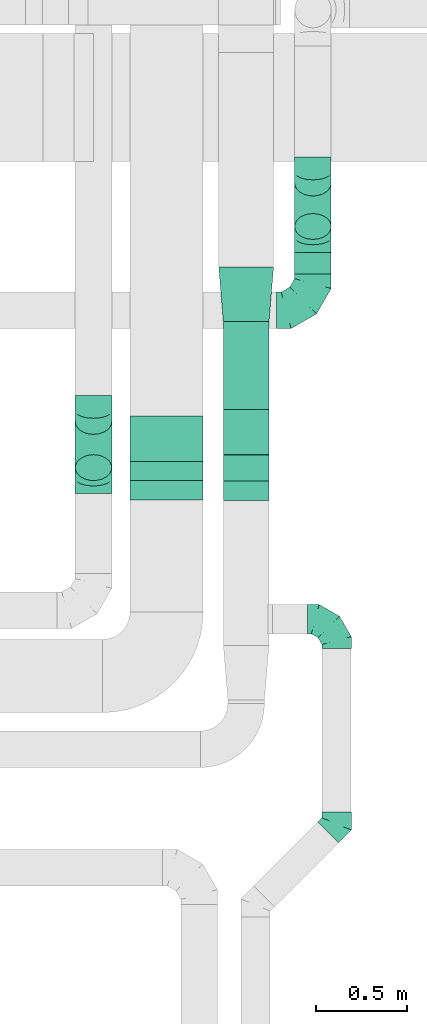
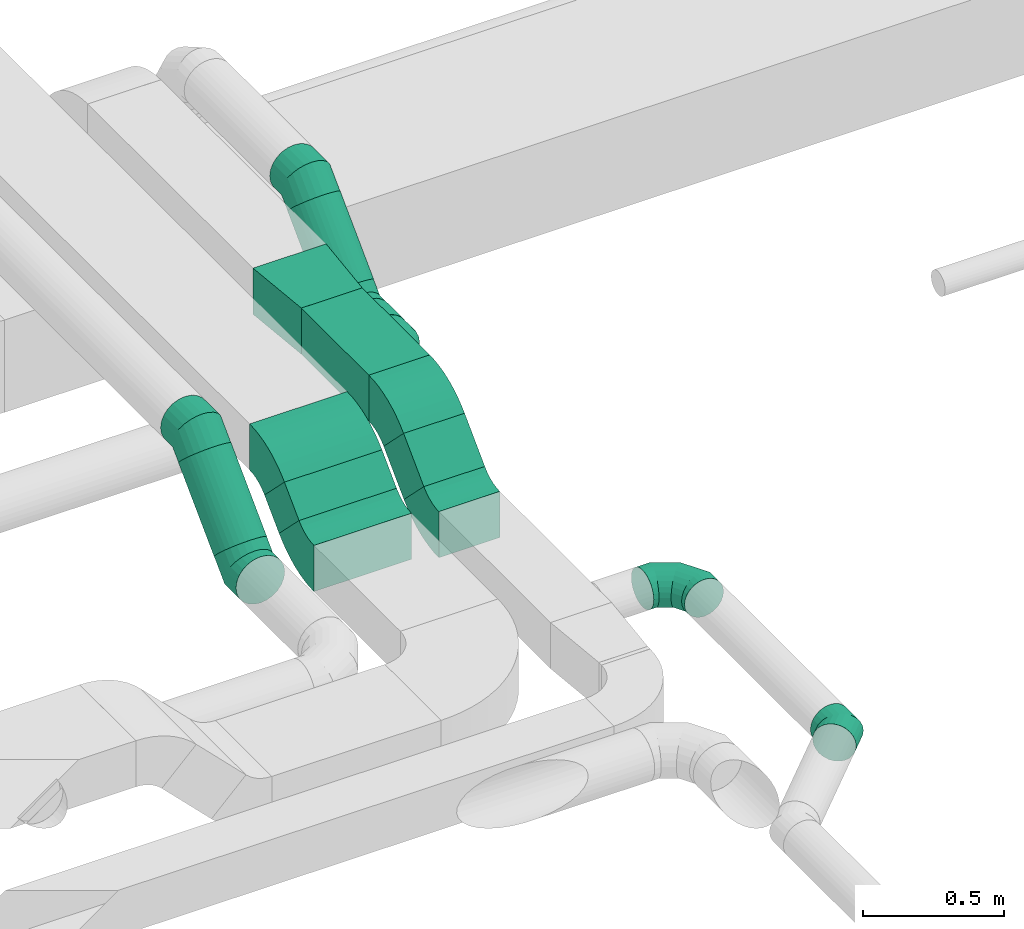
# One storey, part 28 of 60: 12 flow fittings, 6 flow segments.
"""IFC2X3 building model written with IfcOpenShell, lengths in millimetres."""

from ifc_helpers import new_model, entity, si_unit, converted_unit, derived_unit, direction, frame, frame_2d, origin, origin_2d_with_axis, place, context, subcontext, project, spatial, polyline, circle_curve, parameter, trimmed, segment, composite_curve, rectangle, circle, outline, extrude, faceted_brep, source, transform, mapped, material, type_object, type_shapes, element, save


model = new_model("IFC2X3")

# Units and contexts
model_context = context("Model", 3, precision=0.01, world=origin(), true_north=direction((6.12303176911189e-17, 1.0)))
body_context = subcontext(model_context, "Body", "Model", "MODEL_VIEW")
ifc_project = project(units=[si_unit("LENGTHUNIT", "METRE", prefix="MILLI"), si_unit("AREAUNIT", "SQUARE_METRE"), si_unit("VOLUMEUNIT", "CUBIC_METRE"), converted_unit("PLANEANGLEUNIT", "DEGREE", entity("IfcRatioMeasure", 0.0174532925199433), si_unit("PLANEANGLEUNIT", "RADIAN"), dimensions=[0, 0, 0, 0, 0, 0, 0]), si_unit("MASSUNIT", "GRAM", prefix="KILO"), derived_unit("MASSDENSITYUNIT", [(si_unit("MASSUNIT", "GRAM", prefix="KILO"), 1), (si_unit("LENGTHUNIT", "METRE"), -3)]), derived_unit("MOMENTOFINERTIAUNIT", [(si_unit("LENGTHUNIT", "METRE"), 4)]), si_unit("TIMEUNIT", "SECOND"), si_unit("FREQUENCYUNIT", "HERTZ"), si_unit("THERMODYNAMICTEMPERATUREUNIT", "DEGREE_CELSIUS"), derived_unit("THERMALTRANSMITTANCEUNIT", [(si_unit("MASSUNIT", "GRAM", prefix="KILO"), 1), (si_unit("THERMODYNAMICTEMPERATUREUNIT", "KELVIN"), -1), (si_unit("TIMEUNIT", "SECOND"), -3)]), derived_unit("VOLUMETRICFLOWRATEUNIT", [(si_unit("LENGTHUNIT", "METRE"), 3), (si_unit("TIMEUNIT", "SECOND"), -1)]), derived_unit("MASSFLOWRATEUNIT", [(si_unit("MASSUNIT", "GRAM", prefix="KILO"), 1), (si_unit("TIMEUNIT", "SECOND"), -1)]), derived_unit("ROTATIONALFREQUENCYUNIT", [(si_unit("TIMEUNIT", "SECOND"), -1)]), si_unit("ELECTRICCURRENTUNIT", "AMPERE"), si_unit("ELECTRICVOLTAGEUNIT", "VOLT"), si_unit("POWERUNIT", "WATT"), si_unit("FORCEUNIT", "NEWTON", prefix="KILO"), si_unit("ILLUMINANCEUNIT", "LUX"), si_unit("LUMINOUSFLUXUNIT", "LUMEN"), si_unit("LUMINOUSINTENSITYUNIT", "CANDELA"), derived_unit("USERDEFINED", [(si_unit("MASSUNIT", "GRAM", prefix="KILO"), -1), (si_unit("LENGTHUNIT", "METRE"), -2), (si_unit("TIMEUNIT", "SECOND"), 3), (si_unit("LUMINOUSFLUXUNIT", "LUMEN"), 1)]), derived_unit("LINEARVELOCITYUNIT", [(si_unit("LENGTHUNIT", "METRE"), 1), (si_unit("TIMEUNIT", "SECOND"), -1)]), si_unit("PRESSUREUNIT", "PASCAL"), derived_unit("USERDEFINED", [(si_unit("LENGTHUNIT", "METRE"), -2), (si_unit("MASSUNIT", "GRAM", prefix="KILO"), 1), (si_unit("TIMEUNIT", "SECOND"), -2)]), derived_unit("LINEARFORCEUNIT", [(si_unit("MASSUNIT", "GRAM", prefix="KILO"), 1), (si_unit("LENGTHUNIT", "METRE"), 1), (si_unit("TIMEUNIT", "SECOND"), -2), (si_unit("LENGTHUNIT", "METRE"), -1)]), derived_unit("PLANARFORCEUNIT", [(si_unit("MASSUNIT", "GRAM", prefix="KILO"), 1), (si_unit("LENGTHUNIT", "METRE"), 1), (si_unit("TIMEUNIT", "SECOND"), -2), (si_unit("LENGTHUNIT", "METRE"), -2)])], contexts=[model_context])

# Site, building, storey
site_placement = place(None, origin())
site = spatial("IfcSite", under=ifc_project, at=site_placement, CompositionType="ELEMENT")
building_placement = place(site_placement, origin())
building = spatial("IfcBuilding", under=site, at=building_placement, CompositionType="ELEMENT")
storey_placement = place(building_placement, frame((0.0, 0.0, 19800.0)))
storey = spatial("IfcBuildingStorey", under=building, at=storey_placement, CompositionType="ELEMENT", Elevation=19800.0)

# Flow segments
duct_segment_type_1 = type_object("IfcDuctSegmentType", PredefinedType="NOTDEFINED")
flow_segment_1_placement = place(storey_placement, frame((46370.09, 6294.86, 3252.51)))
element("IfcFlowSegment", 1, at=flow_segment_1_placement, inside=storey, type_object=duct_segment_type_1, context=body_context, shape_type="SweptSolid", body=[
    extrude(rectangle(XDim=146.446609406805, YDim=200.0, at=origin_2d_with_axis()), frame((0.0, 122.49, 122.49), z_axis=(1.0, 0.0, 0.0), x_axis=(0.0, 0.707106781186485, 0.70710678118661)), (0.0, 0.0, 1.0), 399.999999999996),
])
flow_segment_2_placement = place(storey_placement, frame((46880.37, 6292.16, 3222.4)))
element("IfcFlowSegment", 2, at=flow_segment_2_placement, inside=storey, type_object=duct_segment_type_1, context=body_context, shape_type="SweptSolid", body=[
    extrude(rectangle(XDim=203.172523765976, YDim=199.999999999999, at=origin_2d_with_axis()), frame((0.0, 142.54, 142.54), z_axis=(1.0, 0.0, 0.0), x_axis=(0.0, 0.707106781186492, 0.707106781186604)), (0.0, 0.0, 1.0), 249.999999999995),
])
flow_segment_3_placement = place(storey_placement, frame((46880.37, 6683.31, 3410.0)))
element("IfcFlowSegment", 3, at=flow_segment_3_placement, inside=storey, type_object=duct_segment_type_1, context=body_context, shape_type="SweptSolid", body=[
    extrude(rectangle(XDim=479.335330694397, YDim=250.000000000004, at=origin_2d_with_axis()), frame((125.0, 239.67, 0.0), z_axis=(0.0, 0.0, 1.0), x_axis=(0.0, -1.0, 0.0)), (0.0, 0.0, 1.0), 199.999999999998),
])
duct_segment_type_2 = type_object("IfcDuctSegmentType", PredefinedType="NOTDEFINED")
flow_segment_4_placement = place(storey_placement, frame((46068.81, 6292.33, 3236.27)))
element("IfcFlowSegment", 4, at=flow_segment_4_placement, inside=storey, type_object=duct_segment_type_2, context=body_context, shape_type="SweptSolid", body=[
    extrude(circle(Radius=100.0, at=origin_2d_with_axis()), frame((101.6, 72.31, 72.31), z_axis=(0.0, 0.707106781186548, 0.707106781186548), x_axis=(-1.0, 0.0, 0.0)), (0.0, 0.0, 1.0), 357.573593128777),
])
flow_segment_5_placement = place(storey_placement, frame((47268.96, 7425.01, 3043.41)))
element("IfcFlowSegment", 5, at=flow_segment_5_placement, inside=storey, type_object=duct_segment_type_2, context=body_context, shape_type="SweptSolid", body=[
    extrude(circle(Radius=100.0, at=origin_2d_with_axis()), frame((101.6, 0.0, 101.6), z_axis=(0.0, 1.0, 0.0), x_axis=(1.0, 0.0, 0.0)), (0.0, 0.0, 1.0), 117.157287525415),
])
flow_segment_6_placement = place(storey_placement, frame((47268.96, 7611.28, 3131.28)))
element("IfcFlowSegment", 6, at=flow_segment_6_placement, inside=storey, type_object=duct_segment_type_2, context=body_context, shape_type="SweptSolid", body=[
    extrude(circle(Radius=100.0, at=origin_2d_with_axis()), frame((101.6, 72.31, 72.31), z_axis=(0.0, 0.707106781186551, 0.707106781186544), x_axis=(-1.0, 0.0, 0.0)), (0.0, 0.0, 1.0), 336.35392118245),
])

# Flow fittings
ifc_material = material()
duct_fitting_type_1 = type_object("IfcDuctFittingType", PredefinedType="NOTDEFINED", material=ifc_material)
shared_shape_1 = source(origin(), body_context, "Body", "SweptSolid", [
    extrude(outline(polyline([(-161.94, -137.03), (139.1, -137.03), (159.86, 112.11), (-137.03, 161.94), (-161.94, -137.03)])), frame((150.0, 0.0, -100.0), z_axis=(0.0, 0.0, 1.0), x_axis=(0.99654575824488, 0.0830454798537381, 0.0)), (0.0, 0.0, 1.0), 200.0),
])
type_shapes(duct_fitting_type_1, [shared_shape_1])
flow_fitting_1_placement = place(storey_placement, frame((47005.37, 7462.65, 3510.0), z_axis=(0.0, 0.0, 1.0), x_axis=(0.0, -1.0, 0.0)))
element("IfcFlowFitting", 7, at=flow_fitting_1_placement, inside=storey, type_object=duct_fitting_type_1, material=ifc_material, context=body_context, shape_type="MappedRepresentation", body=[
    mapped(shared_shape_1, transform((0.0, 0.0, 0.0), scale=1.0)),
])
duct_fitting_type_2 = type_object("IfcDuctFittingType", PredefinedType="NOTDEFINED", material=ifc_material)
shared_shape_2 = source(origin(), body_context, "Body", "Brep", [
    faceted_brep([(-160.0, 0.0, -80.0), (-160.0, -20.71, -77.27), (-160.0, -40.0, -69.28), (-160.0, -56.57, -56.57), (-160.0, -69.28, -40.0), (-160.0, -77.27, -20.71), (-160.0, -80.0, 0.0), (-160.0, -77.27, 20.71), (-160.0, -69.28, 40.0), (-160.0, -56.57, 56.57), (-160.0, -40.0, 69.28), (-160.0, -20.71, 77.27), (-160.0, 0.0, 80.0), (-160.0, 20.71, 77.27), (-160.0, 40.0, 69.28), (-160.0, 56.57, 56.57), (-160.0, 69.28, 40.0), (-160.0, 77.27, 20.71), (-160.0, 80.0, 0.0), (-160.0, 77.27, -20.71), (-160.0, 69.28, -40.0), (-160.0, 56.57, -56.57), (-160.0, 40.0, -69.28), (-160.0, 20.71, -77.27), (-122.68, 20.71, 77.27), (-127.85, 40.0, 69.28), (-117.13, 0.0, 80.0), (-132.29, 56.57, 56.57), (-137.83, 77.27, 20.71), (-138.56, 80.0, 0.0), (-135.69, 69.28, 40.0), (-135.69, 69.28, -40.0), (-132.29, 56.57, -56.57), (-137.83, 77.27, -20.71), (-122.68, 20.71, -77.27), (-117.13, 0.0, -80.0), (-127.85, 40.0, -69.28), (-111.58, -20.71, -77.27), (-106.41, -40.0, -69.28), (-101.97, -56.57, -56.57), (-98.56, -69.28, -40.0), (-96.42, -77.27, -20.71), (-95.69, -80.0, 0.0), (-96.42, -77.27, 20.71), (-98.56, -69.28, 40.0), (-101.97, -56.57, 56.57), (-106.41, -40.0, 69.28), (-111.58, -20.71, 77.27), (-58.03, 58.03, 77.27), (-72.15, 72.15, 69.28), (-42.87, 42.87, 80.0), (-84.28, 84.28, 56.57), (-93.59, 93.59, 40.0), (-99.44, 99.44, 20.71), (-101.44, 101.44, 0.0), (-99.44, 99.44, -20.71), (-93.59, 93.59, -40.0), (-84.28, 84.28, -56.57), (-58.03, 58.03, -77.27), (-42.87, 42.87, -80.0), (-72.15, 72.15, -69.28), (-27.71, 27.71, -77.27), (-13.59, 13.59, -69.28), (-1.46, 1.46, -56.57), (7.85, -7.85, -40.0), (13.7, -13.7, -20.71), (15.69, -15.69, 0.0), (13.7, -13.7, 20.71), (7.85, -7.85, 40.0), (-1.46, 1.46, 56.57), (-13.59, 13.59, 69.28), (-27.71, 27.71, 77.27), (-20.71, 122.68, 77.27), (-40.0, 127.85, 69.28), (0.0, 117.13, 80.0), (-56.57, 132.29, 56.57), (-69.28, 135.69, 40.0), (-77.27, 137.83, 20.71), (-80.0, 138.56, 0.0), (-77.27, 137.83, -20.71), (-69.28, 135.69, -40.0), (-56.57, 132.29, -56.57), (-20.71, 122.68, -77.27), (0.0, 117.13, -80.0), (-40.0, 127.85, -69.28), (20.71, 111.58, -77.27), (40.0, 106.41, -69.28), (56.57, 101.97, -56.57), (69.28, 98.56, -40.0), (77.27, 96.42, -20.71), (80.0, 95.69, 0.0), (77.27, 96.42, 20.71), (69.28, 98.56, 40.0), (56.57, 101.97, 56.57), (40.0, 106.41, 69.28), (20.71, 111.58, 77.27), (-20.71, 160.0, -77.27), (-40.0, 160.0, -69.28), (-56.57, 160.0, -56.57), (-69.28, 160.0, -40.0), (-77.27, 160.0, -20.71), (-80.0, 160.0, 0.0), (-77.27, 160.0, 20.71), (-69.28, 160.0, 40.0), (-56.57, 160.0, 56.57), (-40.0, 160.0, 69.28), (-20.71, 160.0, 77.27), (0.0, 160.0, 80.0), (20.71, 160.0, 77.27), (40.0, 160.0, 69.28), (56.57, 160.0, 56.57), (69.28, 160.0, 40.0), (77.27, 160.0, 20.71), (80.0, 160.0, 0.0), (77.27, 160.0, -20.71), (69.28, 160.0, -40.0), (56.57, 160.0, -56.57), (40.0, 160.0, -69.28), (20.71, 160.0, -77.27), (0.0, 160.0, -80.0)], [[[0, 1, 2, 3, 4, 5, 6, 7, 8, 9, 10, 11, 12, 13, 14, 15, 16, 17, 18, 19, 20, 21, 22, 23]], [[24, 25, 14, 13]], [[26, 24, 13, 12]], [[14, 25, 27, 15]], [[28, 29, 18, 17]], [[30, 28, 17, 16]], [[15, 27, 30, 16]], [[20, 31, 32, 21]], [[33, 31, 20, 19]], [[18, 29, 33, 19]], [[34, 35, 0, 23]], [[36, 34, 23, 22]], [[32, 36, 22, 21]], [[1, 0, 35, 37]], [[2, 1, 37, 38]], [[3, 2, 38, 39]], [[5, 4, 40, 41]], [[6, 5, 41, 42]], [[39, 40, 4, 3]], [[6, 42, 43, 7]], [[7, 43, 44, 8]], [[8, 44, 45, 9]], [[9, 45, 46, 10]], [[10, 46, 47, 11]], [[26, 12, 11, 47]], [[48, 49, 25, 24]], [[50, 48, 24, 26]], [[27, 25, 49, 51]], [[52, 53, 28, 30]], [[51, 52, 30, 27]], [[29, 28, 53, 54]], [[55, 56, 31, 33]], [[54, 55, 33, 29]], [[32, 31, 56, 57]], [[58, 59, 35, 34]], [[60, 58, 34, 36]], [[57, 60, 36, 32]], [[37, 35, 59, 61]], [[38, 37, 61, 62]], [[39, 38, 62, 63]], [[41, 40, 64, 65]], [[42, 41, 65, 66]], [[63, 64, 40, 39]], [[43, 42, 66, 67]], [[44, 43, 67, 68]], [[68, 69, 45, 44]], [[46, 45, 69, 70]], [[47, 46, 70, 71]], [[26, 47, 71, 50]], [[72, 73, 49, 48]], [[74, 72, 48, 50]], [[51, 49, 73, 75]], [[76, 77, 53, 52]], [[75, 76, 52, 51]], [[54, 53, 77, 78]], [[79, 80, 56, 55]], [[78, 79, 55, 54]], [[57, 56, 80, 81]], [[82, 83, 59, 58]], [[84, 82, 58, 60]], [[81, 84, 60, 57]], [[61, 59, 83, 85]], [[62, 61, 85, 86]], [[63, 62, 86, 87]], [[65, 64, 88, 89]], [[66, 65, 89, 90]], [[87, 88, 64, 63]], [[67, 66, 90, 91]], [[68, 67, 91, 92]], [[92, 93, 69, 68]], [[70, 69, 93, 94]], [[71, 70, 94, 95]], [[50, 71, 95, 74]], [[96, 97, 98, 99, 100, 101, 102, 103, 104, 105, 106, 107, 108, 109, 110, 111, 112, 113, 114, 115, 116, 117, 118, 119]], [[72, 74, 107, 106]], [[73, 72, 106, 105]], [[75, 73, 105, 104]], [[77, 76, 103, 102]], [[78, 77, 102, 101]], [[75, 104, 103, 76]], [[78, 101, 100, 79]], [[79, 100, 99, 80]], [[80, 99, 98, 81]], [[84, 97, 96, 82]], [[82, 96, 119, 83]], [[84, 81, 98, 97]], [[118, 117, 86, 85]], [[119, 118, 85, 83]], [[116, 87, 86, 117]], [[88, 115, 114, 89]], [[89, 114, 113, 90]], [[115, 88, 87, 116]], [[112, 111, 92, 91]], [[113, 112, 91, 90]], [[111, 110, 93, 92]], [[95, 94, 109, 108]], [[74, 95, 108, 107]], [[110, 109, 94, 93]]]),
])
type_shapes(duct_fitting_type_2, [shared_shape_2])
flow_fitting_2_placement = place(storey_placement, frame((47500.37, 5535.94, 3219.89), z_axis=(0.0, 0.0, 1.0), x_axis=(0.0, 1.0, 0.0)))
element("IfcFlowFitting", 8, at=flow_fitting_2_placement, inside=storey, type_object=duct_fitting_type_2, material=ifc_material, context=body_context, shape_type="MappedRepresentation", body=[
    mapped(shared_shape_2, transform((0.0, 0.0, 0.0), scale=1.0)),
])
duct_fitting_type_3 = type_object("IfcDuctFittingType", PredefinedType="NOTDEFINED", material=ifc_material)
shared_shape_3 = source(origin(), body_context, "Body", "Brep", [
    faceted_brep([(-200.0, 0.0, -100.0), (-200.0, -25.88, -96.59), (-200.0, -50.0, -86.6), (-200.0, -70.71, -70.71), (-200.0, -86.6, -50.0), (-200.0, -96.59, -25.88), (-200.0, -100.0, 0.0), (-200.0, -96.59, 25.88), (-200.0, -86.6, 50.0), (-200.0, -70.71, 70.71), (-200.0, -50.0, 86.6), (-200.0, -25.88, 96.59), (-200.0, 0.0, 100.0), (-200.0, 25.88, 96.59), (-200.0, 50.0, 86.6), (-200.0, 70.71, 70.71), (-200.0, 86.6, 50.0), (-200.0, 96.59, 25.88), (-200.0, 100.0, 0.0), (-200.0, 96.59, -25.88), (-200.0, 86.6, -50.0), (-200.0, 70.71, -70.71), (-200.0, 50.0, -86.6), (-200.0, 25.88, -96.59), (-153.35, 25.88, 96.59), (-159.81, 50.0, 86.6), (-146.41, 0.0, 100.0), (-165.36, 70.71, 70.71), (-172.29, 96.59, 25.88), (-173.21, 100.0, 0.0), (-169.62, 86.6, 50.0), (-169.62, 86.6, -50.0), (-165.36, 70.71, -70.71), (-172.29, 96.59, -25.88), (-153.35, 25.88, -96.59), (-146.41, 0.0, -100.0), (-159.81, 50.0, -86.6), (-139.48, -25.88, -96.59), (-133.01, -50.0, -86.6), (-127.46, -70.71, -70.71), (-123.21, -86.6, -50.0), (-120.53, -96.59, -25.88), (-119.62, -100.0, 0.0), (-120.53, -96.59, 25.88), (-123.21, -86.6, 50.0), (-127.46, -70.71, 70.71), (-133.01, -50.0, 86.6), (-139.48, -25.88, 96.59), (-72.54, 72.54, 96.59), (-90.19, 90.19, 86.6), (-53.59, 53.59, 100.0), (-105.35, 105.35, 70.71), (-116.99, 116.99, 50.0), (-124.3, 124.3, 25.88), (-126.79, 126.79, 0.0), (-124.3, 124.3, -25.88), (-116.99, 116.99, -50.0), (-105.35, 105.35, -70.71), (-72.54, 72.54, -96.59), (-53.59, 53.59, -100.0), (-90.19, 90.19, -86.6), (-34.64, 34.64, -96.59), (-16.99, 16.99, -86.6), (-1.83, 1.83, -70.71), (9.81, -9.81, -50.0), (17.12, -17.12, -25.88), (19.62, -19.62, 0.0), (17.12, -17.12, 25.88), (9.81, -9.81, 50.0), (-1.83, 1.83, 70.71), (-16.99, 16.99, 86.6), (-34.64, 34.64, 96.59), (-25.88, 153.35, 96.59), (-50.0, 159.81, 86.6), (0.0, 146.41, 100.0), (-70.71, 165.36, 70.71), (-86.6, 169.62, 50.0), (-96.59, 172.29, 25.88), (-100.0, 173.21, 0.0), (-96.59, 172.29, -25.88), (-86.6, 169.62, -50.0), (-70.71, 165.36, -70.71), (-25.88, 153.35, -96.59), (0.0, 146.41, -100.0), (-50.0, 159.81, -86.6), (25.88, 139.48, -96.59), (50.0, 133.01, -86.6), (70.71, 127.46, -70.71), (86.6, 123.21, -50.0), (96.59, 120.53, -25.88), (100.0, 119.62, 0.0), (96.59, 120.53, 25.88), (86.6, 123.21, 50.0), (70.71, 127.46, 70.71), (50.0, 133.01, 86.6), (25.88, 139.48, 96.59), (-25.88, 200.0, -96.59), (-50.0, 200.0, -86.6), (-70.71, 200.0, -70.71), (-86.6, 200.0, -50.0), (-96.59, 200.0, -25.88), (-100.0, 200.0, 0.0), (-96.59, 200.0, 25.88), (-86.6, 200.0, 50.0), (-70.71, 200.0, 70.71), (-50.0, 200.0, 86.6), (-25.88, 200.0, 96.59), (0.0, 200.0, 100.0), (25.88, 200.0, 96.59), (50.0, 200.0, 86.6), (70.71, 200.0, 70.71), (86.6, 200.0, 50.0), (96.59, 200.0, 25.88), (100.0, 200.0, 0.0), (96.59, 200.0, -25.88), (86.6, 200.0, -50.0), (70.71, 200.0, -70.71), (50.0, 200.0, -86.6), (25.88, 200.0, -96.59), (0.0, 200.0, -100.0)], [[[0, 1, 2, 3, 4, 5, 6, 7, 8, 9, 10, 11, 12, 13, 14, 15, 16, 17, 18, 19, 20, 21, 22, 23]], [[24, 25, 14, 13]], [[26, 24, 13, 12]], [[14, 25, 27, 15]], [[28, 29, 18, 17]], [[30, 28, 17, 16]], [[15, 27, 30, 16]], [[20, 31, 32, 21]], [[33, 31, 20, 19]], [[18, 29, 33, 19]], [[34, 35, 0, 23]], [[36, 34, 23, 22]], [[32, 36, 22, 21]], [[1, 0, 35, 37]], [[2, 1, 37, 38]], [[38, 39, 3, 2]], [[5, 4, 40, 41]], [[6, 5, 41, 42]], [[39, 40, 4, 3]], [[6, 42, 43, 7]], [[7, 43, 44, 8]], [[8, 44, 45, 9]], [[9, 45, 46, 10]], [[10, 46, 47, 11]], [[26, 12, 11, 47]], [[48, 49, 25, 24]], [[50, 48, 24, 26]], [[27, 25, 49, 51]], [[52, 53, 28, 30]], [[51, 52, 30, 27]], [[29, 28, 53, 54]], [[55, 56, 31, 33]], [[54, 55, 33, 29]], [[32, 31, 56, 57]], [[58, 59, 35, 34]], [[60, 58, 34, 36]], [[57, 60, 36, 32]], [[37, 35, 59, 61]], [[38, 37, 61, 62]], [[39, 38, 62, 63]], [[41, 40, 64, 65]], [[42, 41, 65, 66]], [[63, 64, 40, 39]], [[43, 42, 66, 67]], [[44, 43, 67, 68]], [[68, 69, 45, 44]], [[46, 45, 69, 70]], [[47, 46, 70, 71]], [[26, 47, 71, 50]], [[72, 73, 49, 48]], [[74, 72, 48, 50]], [[51, 49, 73, 75]], [[76, 77, 53, 52]], [[75, 76, 52, 51]], [[54, 53, 77, 78]], [[79, 80, 56, 55]], [[78, 79, 55, 54]], [[57, 56, 80, 81]], [[82, 83, 59, 58]], [[84, 82, 58, 60]], [[81, 84, 60, 57]], [[61, 59, 83, 85]], [[62, 61, 85, 86]], [[63, 62, 86, 87]], [[65, 64, 88, 89]], [[66, 65, 89, 90]], [[87, 88, 64, 63]], [[67, 66, 90, 91]], [[68, 67, 91, 92]], [[92, 93, 69, 68]], [[70, 69, 93, 94]], [[71, 70, 94, 95]], [[50, 71, 95, 74]], [[96, 97, 98, 99, 100, 101, 102, 103, 104, 105, 106, 107, 108, 109, 110, 111, 112, 113, 114, 115, 116, 117, 118, 119]], [[72, 74, 107, 106]], [[73, 72, 106, 105]], [[75, 73, 105, 104]], [[102, 101, 78, 77]], [[103, 102, 77, 76]], [[75, 104, 103, 76]], [[78, 101, 100, 79]], [[79, 100, 99, 80]], [[80, 99, 98, 81]], [[84, 97, 96, 82]], [[82, 96, 119, 83]], [[84, 81, 98, 97]], [[118, 117, 86, 85]], [[119, 118, 85, 83]], [[116, 87, 86, 117]], [[88, 115, 114, 89]], [[89, 114, 113, 90]], [[115, 88, 87, 116]], [[91, 90, 113, 112]], [[92, 91, 112, 111]], [[111, 110, 93, 92]], [[95, 94, 109, 108]], [[74, 95, 108, 107]], [[110, 109, 94, 93]]]),
])
type_shapes(duct_fitting_type_3, [shared_shape_3])
flow_fitting_3_placement = place(storey_placement, frame((47370.56, 7225.01, 3145.0)))
element("IfcFlowFitting", 9, at=flow_fitting_3_placement, inside=storey, type_object=duct_fitting_type_3, material=ifc_material, context=body_context, shape_type="MappedRepresentation", body=[
    mapped(shared_shape_3, transform((0.0, 0.0, 0.0), scale=1.0)),
])
duct_fitting_type_4 = type_object("IfcDuctFittingType", PredefinedType="NOTDEFINED", material=ifc_material)
shared_shape_4 = source(origin(), body_context, "Body", "Brep", [
    faceted_brep([(-66.27, 0.0, -80.0), (-66.27, -20.71, -77.27), (-66.27, -40.0, -69.28), (-66.27, -56.57, -56.57), (-66.27, -69.28, -40.0), (-66.27, -77.27, -20.71), (-66.27, -80.0, 0.0), (-66.27, -77.27, 20.71), (-66.27, -69.28, 40.0), (-66.27, -56.57, 56.57), (-66.27, -40.0, 69.28), (-66.27, -20.71, 77.27), (-66.27, 0.0, 80.0), (-66.27, 20.71, 77.27), (-66.27, 40.0, 69.28), (-66.27, 56.57, 56.57), (-66.27, 69.28, 40.0), (-66.27, 77.27, 20.71), (-66.27, 80.0, 0.0), (-66.27, 77.27, -20.71), (-66.27, 69.28, -40.0), (-66.27, 56.57, -56.57), (-66.27, 40.0, -69.28), (-66.27, 20.71, -77.27), (-8.58, 20.71, 77.27), (-16.57, 40.0, 69.28), (0.0, 0.0, 80.0), (-23.43, 56.57, 56.57), (-28.7, 69.28, 40.0), (-32.01, 77.27, 20.71), (-33.14, 80.0, 0.0), (-32.01, 77.27, -20.71), (-28.7, 69.28, -40.0), (-23.43, 56.57, -56.57), (-8.58, 20.71, -77.27), (0.0, 0.0, -80.0), (-16.57, 40.0, -69.28), (8.58, -20.71, -77.27), (16.57, -40.0, -69.28), (23.43, -56.57, -56.57), (28.7, -69.28, -40.0), (32.01, -77.27, -20.71), (33.14, -80.0, 0.0), (32.01, -77.27, 20.71), (28.7, -69.28, 40.0), (23.43, -56.57, 56.57), (16.57, -40.0, 69.28), (8.58, -20.71, 77.27), (46.86, 46.86, 80.0), (32.22, 61.5, 77.27), (18.58, 75.15, 69.28), (6.86, 86.86, 56.57), (-2.13, 95.85, 40.0), (-7.78, 101.5, 20.71), (-9.71, 103.43, 0.0), (-7.78, 101.5, -20.71), (-2.13, 95.85, -40.0), (6.86, 86.86, -56.57), (18.58, 75.15, -69.28), (32.22, 61.5, -77.27), (46.86, 46.86, -80.0), (61.5, 32.22, -77.27), (75.15, 18.58, -69.28), (86.86, 6.86, -56.57), (95.85, -2.13, -40.0), (101.5, -7.78, -20.71), (103.43, -9.71, 0.0), (101.5, -7.78, 20.71), (95.85, -2.13, 40.0), (86.86, 6.86, 56.57), (75.15, 18.58, 69.28), (61.5, 32.22, 77.27)], [[[0, 1, 2, 3, 4, 5, 6, 7, 8, 9, 10, 11, 12, 13, 14, 15, 16, 17, 18, 19, 20, 21, 22, 23]], [[24, 25, 14, 13]], [[26, 24, 13, 12]], [[14, 25, 27, 15]], [[28, 29, 17, 16]], [[28, 16, 15, 27]], [[30, 18, 17, 29]], [[31, 32, 20, 19]], [[30, 31, 19, 18]], [[32, 33, 21, 20]], [[34, 35, 0, 23]], [[36, 34, 23, 22]], [[33, 36, 22, 21]], [[1, 0, 35, 37]], [[2, 1, 37, 38]], [[38, 39, 3, 2]], [[5, 4, 40, 41]], [[6, 5, 41, 42]], [[39, 40, 4, 3]], [[6, 42, 43, 7]], [[7, 43, 44, 8]], [[8, 44, 45, 9]], [[9, 45, 46, 10]], [[10, 46, 47, 11]], [[26, 12, 11, 47]], [[24, 26, 48, 49]], [[25, 24, 49, 50]], [[27, 25, 50, 51]], [[29, 28, 52, 53]], [[30, 29, 53, 54]], [[51, 52, 28, 27]], [[30, 54, 55, 31]], [[31, 55, 56, 32]], [[57, 33, 32, 56]], [[36, 58, 59, 34]], [[34, 59, 60, 35]], [[58, 36, 33, 57]], [[35, 60, 61, 37]], [[37, 61, 62, 38]], [[63, 39, 38, 62]], [[40, 64, 65, 41]], [[41, 65, 66, 42]], [[64, 40, 39, 63]], [[43, 42, 66, 67]], [[44, 43, 67, 68]], [[68, 69, 45, 44]], [[47, 46, 70, 71]], [[26, 47, 71, 48]], [[69, 70, 46, 45]], [[59, 58, 57, 56, 55, 54, 53, 52, 51, 50, 49, 48, 71, 70, 69, 68, 67, 66, 65, 64, 63, 62, 61, 60]]]),
])
type_shapes(duct_fitting_type_4, [shared_shape_4])
flow_fitting_4_placement = place(storey_placement, frame((47500.37, 4415.94, 3219.89), z_axis=(0.0, 0.0, 1.0), x_axis=(0.707106781186545, 0.70710678118655, 0.0)))
element("IfcFlowFitting", 10, at=flow_fitting_4_placement, inside=storey, type_object=duct_fitting_type_4, material=ifc_material, context=body_context, shape_type="MappedRepresentation", body=[
    mapped(shared_shape_4, transform((0.0, 0.0, 0.0), scale=1.0)),
])
duct_fitting_type_5 = type_object("IfcDuctFittingType", PredefinedType="NOTDEFINED", material=ifc_material)
shared_shape_5 = source(origin(), body_context, "Body", "Brep", [
    faceted_brep([(-82.84, 0.0, -100.0), (-82.84, -25.88, -96.59), (-82.84, -50.0, -86.6), (-82.84, -70.71, -70.71), (-82.84, -86.6, -50.0), (-82.84, -96.59, -25.88), (-82.84, -100.0, 0.0), (-82.84, -96.59, 25.88), (-82.84, -86.6, 50.0), (-82.84, -70.71, 70.71), (-82.84, -50.0, 86.6), (-82.84, -25.88, 96.59), (-82.84, 0.0, 100.0), (-82.84, 25.88, 96.59), (-82.84, 50.0, 86.6), (-82.84, 70.71, 70.71), (-82.84, 86.6, 50.0), (-82.84, 96.59, 25.88), (-82.84, 100.0, 0.0), (-82.84, 96.59, -25.88), (-82.84, 86.6, -50.0), (-82.84, 70.71, -70.71), (-82.84, 50.0, -86.6), (-82.84, 25.88, -96.59), (-10.72, 25.88, 96.59), (-20.71, 50.0, 86.6), (0.0, 0.0, 100.0), (-29.29, 70.71, 70.71), (-35.87, 86.6, 50.0), (-40.01, 96.59, 25.88), (-41.42, 100.0, 0.0), (-40.01, 96.59, -25.88), (-35.87, 86.6, -50.0), (-29.29, 70.71, -70.71), (-10.72, 25.88, -96.59), (0.0, 0.0, -100.0), (-20.71, 50.0, -86.6), (10.72, -25.88, -96.59), (20.71, -50.0, -86.6), (29.29, -70.71, -70.71), (35.87, -86.6, -50.0), (40.01, -96.59, -25.88), (41.42, -100.0, 0.0), (40.01, -96.59, 25.88), (35.87, -86.6, 50.0), (29.29, -70.71, 70.71), (20.71, -50.0, 86.6), (10.72, -25.88, 96.59), (58.58, 58.58, 100.0), (40.28, 76.88, 96.59), (23.22, 93.93, 86.6), (8.58, 108.58, 70.71), (-2.66, 119.82, 50.0), (-9.72, 126.88, 25.88), (-12.13, 129.29, 0.0), (-9.72, 126.88, -25.88), (-2.66, 119.82, -50.0), (8.58, 108.58, -70.71), (23.22, 93.93, -86.6), (40.28, 76.88, -96.59), (58.58, 58.58, -100.0), (76.88, 40.28, -96.59), (93.93, 23.22, -86.6), (108.58, 8.58, -70.71), (119.82, -2.66, -50.0), (126.88, -9.72, -25.88), (129.29, -12.13, 0.0), (126.88, -9.72, 25.88), (119.82, -2.66, 50.0), (108.58, 8.58, 70.71), (93.93, 23.22, 86.6), (76.88, 40.28, 96.59)], [[[0, 1, 2, 3, 4, 5, 6, 7, 8, 9, 10, 11, 12, 13, 14, 15, 16, 17, 18, 19, 20, 21, 22, 23]], [[24, 25, 14, 13]], [[26, 24, 13, 12]], [[14, 25, 27, 15]], [[28, 29, 17, 16]], [[28, 16, 15, 27]], [[30, 18, 17, 29]], [[31, 32, 20, 19]], [[30, 31, 19, 18]], [[32, 33, 21, 20]], [[34, 35, 0, 23]], [[36, 34, 23, 22]], [[33, 36, 22, 21]], [[1, 0, 35, 37]], [[2, 1, 37, 38]], [[38, 39, 3, 2]], [[5, 4, 40, 41]], [[6, 5, 41, 42]], [[39, 40, 4, 3]], [[6, 42, 43, 7]], [[7, 43, 44, 8]], [[8, 44, 45, 9]], [[9, 45, 46, 10]], [[10, 46, 47, 11]], [[26, 12, 11, 47]], [[24, 26, 48, 49]], [[25, 24, 49, 50]], [[27, 25, 50, 51]], [[29, 28, 52, 53]], [[30, 29, 53, 54]], [[51, 52, 28, 27]], [[30, 54, 55, 31]], [[31, 55, 56, 32]], [[57, 33, 32, 56]], [[36, 58, 59, 34]], [[34, 59, 60, 35]], [[58, 36, 33, 57]], [[35, 60, 61, 37]], [[37, 61, 62, 38]], [[63, 39, 38, 62]], [[40, 64, 65, 41]], [[41, 65, 66, 42]], [[64, 40, 39, 63]], [[43, 42, 66, 67]], [[44, 43, 67, 68]], [[68, 69, 45, 44]], [[47, 46, 70, 71]], [[26, 47, 71, 48]], [[69, 70, 46, 45]], [[59, 58, 57, 56, 55, 54, 53, 52, 51, 50, 49, 48, 71, 70, 69, 68, 67, 66, 65, 64, 63, 62, 61, 60]]]),
])
type_shapes(duct_fitting_type_5, [shared_shape_5])
for number, where, z_axis, x_axis in (
    (11, (46170.4, 6306.05, 3250.0), (-1.0, 0.0, 0.0), (0.0, -0.707106781186493, -0.707106781186602)),
    (12, (46170.4, 6676.05, 3620.0), (-1.0, 0.0, 0.0), (0.0, 0.707106781186472, 0.707106781186623)),
    (13, (47370.56, 7980.0, 3500.0), (1.0, 0.0, 0.0), (0.0, -1.0, 0.0)),
    (14, (47370.56, 7625.01, 3145.0), (1.0, 0.0, 0.0), (0.0, 1.0, 0.0)),
):
    element("IfcFlowFitting", number, at=place(storey_placement, frame(where, z_axis=z_axis, x_axis=x_axis)), inside=storey, type_object=duct_fitting_type_5, material=ifc_material, context=body_context, shape_type="MappedRepresentation", body=[
        mapped(shared_shape_5, transform((0.0, 0.0, 0.0), scale=1.0)),
    ])
duct_fitting_type_6 = type_object("IfcDuctFittingType", PredefinedType="NOTDEFINED", material=ifc_material)
shared_shape_6 = source(origin(), body_context, "Body", "SweptSolid", [
    extrude(outline(composite_curve([segment(polyline([(-136.61, -88.39), (63.39, -88.39)]), True, "CONTINUOUS"), segment(trimmed(circle_curve(frame_2d((213.39, -88.39), x_axis=(-0.707106781186546, 0.707106781186546)), 150.0), [parameter(0.0)], [parameter(45.0)], True, "PARAMETER"), False, "CONTINUOUS"), segment(polyline([(107.32, 17.68), (-34.1, 159.1)]), True, "CONTINUOUS"), segment(trimmed(circle_curve(frame_2d((213.39, -88.39), x_axis=(-0.707106781186546, 0.707106781186546)), 350.0), [parameter(0.0)], [parameter(45.0)], True, "PARAMETER"), True, "CONTINUOUS")], self_intersect=False)), frame((-15.17, 36.61, -125.0), z_axis=(0.0, 0.0, 1.0), x_axis=(-0.707106781186547, 0.707106781186548, 0.0)), (0.0, 0.0, 1.0), 250.0),
])
type_shapes(duct_fitting_type_6, [shared_shape_6])
for number, where, z_axis, x_axis in (
    (15, (47005.37, 6289.65, 3219.89), (1.0, 0.0, 0.0), (0.0, 1.0, 0.0)),
    (16, (47005.37, 6579.76, 3510.0), (-1.0, 0.0, 0.0), (0.0, 0.707106781186485, 0.70710678118661)),
):
    element("IfcFlowFitting", number, at=place(storey_placement, frame(where, z_axis=z_axis, x_axis=x_axis)), inside=storey, type_object=duct_fitting_type_6, material=ifc_material, context=body_context, shape_type="MappedRepresentation", body=[
        mapped(shared_shape_6, transform((0.0, 0.0, 0.0), scale=1.0)),
    ])
duct_fitting_type_7 = type_object("IfcDuctFittingType", PredefinedType="NOTDEFINED", material=ifc_material)
shared_shape_7 = source(origin(), body_context, "Body", "SweptSolid", [
    extrude(outline(composite_curve([segment(polyline([(-136.61, -88.39), (63.39, -88.39)]), True, "CONTINUOUS"), segment(trimmed(circle_curve(frame_2d((213.39, -88.39), x_axis=(-0.707106781186546, 0.707106781186546)), 150.0), [parameter(0.0)], [parameter(45.0)], True, "PARAMETER"), False, "CONTINUOUS"), segment(polyline([(107.32, 17.68), (-34.1, 159.1)]), True, "CONTINUOUS"), segment(trimmed(circle_curve(frame_2d((213.39, -88.39), x_axis=(-0.707106781186546, 0.707106781186546)), 350.0), [parameter(0.0)], [parameter(45.0)], True, "PARAMETER"), True, "CONTINUOUS")], self_intersect=False)), frame((-15.17, 36.61, -200.0), z_axis=(0.0, 0.0, 1.0), x_axis=(-0.707106781186547, 0.707106781186548, 0.0)), (0.0, 0.0, 1.0), 400.0),
])
type_shapes(duct_fitting_type_7, [shared_shape_7])
for number, where, z_axis, x_axis in (
    (17, (46570.09, 6292.34, 3250.0), (1.0, 0.0, 0.0), (0.0, 1.0, 0.0)),
    (18, (46570.09, 6542.34, 3500.0), (-1.0, 0.0, 0.0), (0.0, 0.707106781186485, 0.70710678118661)),
):
    element("IfcFlowFitting", number, at=place(storey_placement, frame(where, z_axis=z_axis, x_axis=x_axis)), inside=storey, type_object=duct_fitting_type_7, material=ifc_material, context=body_context, shape_type="MappedRepresentation", body=[
        mapped(shared_shape_7, transform((0.0, 0.0, 0.0), scale=1.0)),
    ])

save(model, "model.ifc")
